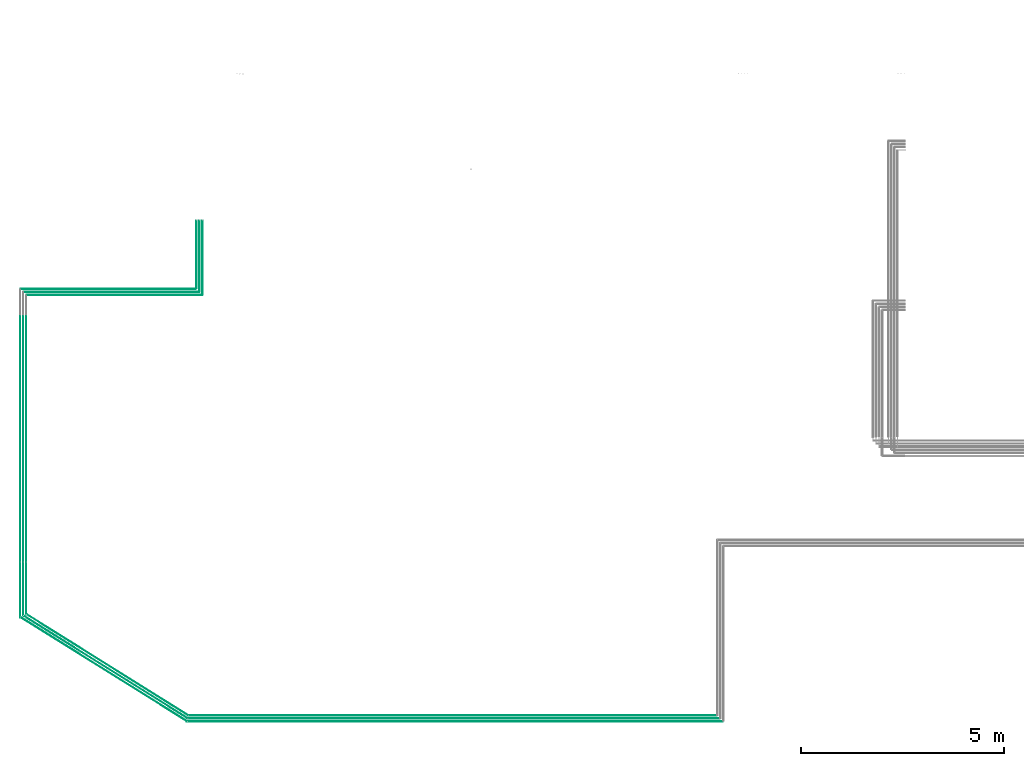
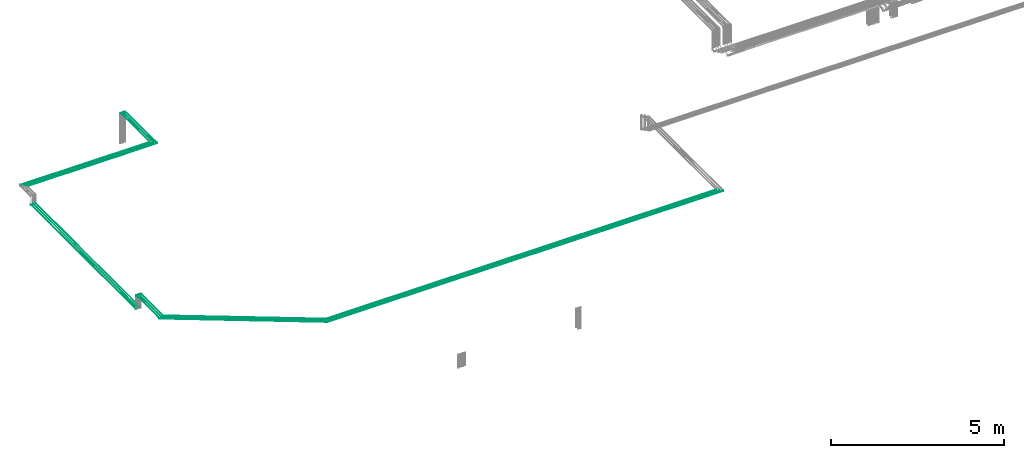
# One storey, part 1 of 65: 18 flow segments.
"""IFC2X3 building model written with IfcOpenShell, lengths in millimetres."""

from ifc_helpers import new_model, entity, si_unit, converted_unit, derived_unit, direction, frame, frame_2d, origin, origin_2d_with_axis, place, context, subcontext, project, spatial, circle, extrude, type_object, element, save


model = new_model("IFC2X3")

# Units and contexts
model_context = context("Model", 3, precision=0.01, world=origin(), true_north=direction((6.12303176911189e-17, 1.0)))
body_context = subcontext(model_context, "Body", "Model", "MODEL_VIEW")
ifc_project = project(units=[si_unit("LENGTHUNIT", "METRE", prefix="MILLI"), si_unit("AREAUNIT", "SQUARE_METRE"), si_unit("VOLUMEUNIT", "CUBIC_METRE"), converted_unit("PLANEANGLEUNIT", "DEGREE", entity("IfcRatioMeasure", 0.0174532925199433), si_unit("PLANEANGLEUNIT", "RADIAN"), dimensions=[0, 0, 0, 0, 0, 0, 0]), si_unit("MASSUNIT", "GRAM", prefix="KILO"), derived_unit("MASSDENSITYUNIT", [(si_unit("MASSUNIT", "GRAM", prefix="KILO"), 1), (si_unit("LENGTHUNIT", "METRE"), -3)]), derived_unit("MOMENTOFINERTIAUNIT", [(si_unit("LENGTHUNIT", "METRE"), 4)]), si_unit("TIMEUNIT", "SECOND"), si_unit("FREQUENCYUNIT", "HERTZ"), si_unit("THERMODYNAMICTEMPERATUREUNIT", "DEGREE_CELSIUS"), derived_unit("THERMALTRANSMITTANCEUNIT", [(si_unit("MASSUNIT", "GRAM", prefix="KILO"), 1), (si_unit("THERMODYNAMICTEMPERATUREUNIT", "KELVIN"), -1), (si_unit("TIMEUNIT", "SECOND"), -3)]), derived_unit("VOLUMETRICFLOWRATEUNIT", [(si_unit("LENGTHUNIT", "METRE"), 3), (si_unit("TIMEUNIT", "SECOND"), -1)]), derived_unit("MASSFLOWRATEUNIT", [(si_unit("MASSUNIT", "GRAM", prefix="KILO"), 1), (si_unit("TIMEUNIT", "SECOND"), -1)]), derived_unit("ROTATIONALFREQUENCYUNIT", [(si_unit("TIMEUNIT", "SECOND"), -1)]), si_unit("ELECTRICCURRENTUNIT", "AMPERE"), si_unit("ELECTRICVOLTAGEUNIT", "VOLT"), si_unit("POWERUNIT", "WATT"), si_unit("FORCEUNIT", "NEWTON", prefix="KILO"), si_unit("ILLUMINANCEUNIT", "LUX"), si_unit("LUMINOUSFLUXUNIT", "LUMEN"), si_unit("LUMINOUSINTENSITYUNIT", "CANDELA"), derived_unit("USERDEFINED", [(si_unit("MASSUNIT", "GRAM", prefix="KILO"), -1), (si_unit("LENGTHUNIT", "METRE"), -2), (si_unit("TIMEUNIT", "SECOND"), 3), (si_unit("LUMINOUSFLUXUNIT", "LUMEN"), 1)]), derived_unit("LINEARVELOCITYUNIT", [(si_unit("LENGTHUNIT", "METRE"), 1), (si_unit("TIMEUNIT", "SECOND"), -1)]), si_unit("PRESSUREUNIT", "PASCAL"), derived_unit("USERDEFINED", [(si_unit("LENGTHUNIT", "METRE"), -2), (si_unit("MASSUNIT", "GRAM", prefix="KILO"), 1), (si_unit("TIMEUNIT", "SECOND"), -2)]), derived_unit("LINEARFORCEUNIT", [(si_unit("MASSUNIT", "GRAM", prefix="KILO"), 1), (si_unit("LENGTHUNIT", "METRE"), 1), (si_unit("TIMEUNIT", "SECOND"), -2), (si_unit("LENGTHUNIT", "METRE"), -1)]), derived_unit("PLANARFORCEUNIT", [(si_unit("MASSUNIT", "GRAM", prefix="KILO"), 1), (si_unit("LENGTHUNIT", "METRE"), 1), (si_unit("TIMEUNIT", "SECOND"), -2), (si_unit("LENGTHUNIT", "METRE"), -2)])], contexts=[model_context])

# Site, building, storey
site_placement = place(None, frame((0.0, -0.00077364408347762, 0.0)))
site = spatial("IfcSite", under=ifc_project, at=site_placement, CompositionType="ELEMENT")
building_placement = place(site_placement, origin())
building = spatial("IfcBuilding", under=site, at=building_placement, CompositionType="ELEMENT")
storey_placement = place(building_placement, frame((0.0, 0.0, 19800.0)))
storey = spatial("IfcBuildingStorey", under=building, at=storey_placement, CompositionType="ELEMENT", Elevation=19800.0)

# Flow segments
pipe_segment_type = type_object("IfcPipeSegmentType", PredefinedType="NOTDEFINED")
flow_segment_1_placement = place(storey_placement, frame((16322.4047325917, 4299.93203955569, 2542.40472776409)))
element("IfcFlowSegment", 1, at=flow_segment_1_placement, inside=storey, type_object=pipe_segment_type, context=body_context, shape_type="SweptSolid", body=[
    extrude(circle(Radius=6.0, at=frame_2d((-6.49720277579036e-12, 0.0), x_axis=(1.0, 0.0))), frame((7.5952722359232, 0.0, 7.59527223591454), z_axis=(0.0, 1.0, 0.0), x_axis=(-1.0, 0.0, 0.0)), (0.0, 0.0, 1.0), 6064.81988032207),
])
flow_segment_2_placement = place(storey_placement, frame((16490.0, 10859.5344917542, 2844.40472776409)))
element("IfcFlowSegment", 2, at=flow_segment_2_placement, inside=storey, type_object=pipe_segment_type, context=body_context, shape_type="SweptSolid", body=[
    extrude(circle(Radius=4.0, at=frame_2d((-6.49720277579036e-12, 0.0), x_axis=(1.0, 0.0))), frame((0.0, 5.59527223591932, 5.59527223591499), z_axis=(1.0, 0.0, 0.0), x_axis=(0.0, 1.0, 0.0)), (0.0, 0.0, 1.0), 4325.10853012706),
])
flow_segment_3_placement = place(storey_placement, frame((16415.0, 10934.5344917542, 2844.40472776409)))
element("IfcFlowSegment", 3, at=flow_segment_3_placement, inside=storey, type_object=pipe_segment_type, context=body_context, shape_type="SweptSolid", body=[
    extrude(circle(Radius=4.0, at=frame_2d((-6.49720277579036e-12, 0.0), x_axis=(1.0, 0.0))), frame((0.0, 5.59527223591932, 5.59527223591499), z_axis=(1.0, 0.0, 0.0), x_axis=(0.0, 1.0, 0.0)), (0.0, 0.0, 1.0), 4325.10853012718),
])
flow_segment_4_placement = place(storey_placement, frame((16344.0, 11007.5344917542, 2842.40472776409)))
element("IfcFlowSegment", 4, at=flow_segment_4_placement, inside=storey, type_object=pipe_segment_type, context=body_context, shape_type="SweptSolid", body=[
    extrude(circle(Radius=6.0, at=frame_2d((-4.33146851719357e-12, 0.0), x_axis=(1.0, 0.0))), frame((0.0, 7.59527223592103, 7.59527223591454), z_axis=(1.0, 0.0, 0.0), x_axis=(0.0, 1.0, 0.0)), (0.0, 0.0, 1.0), 4317.10853012719),
])
flow_segment_5_placement = place(storey_placement, frame((20459.8637699032, 342.404727764186, 3042.40472776409)))
element("IfcFlowSegment", 5, at=flow_segment_5_placement, inside=storey, type_object=pipe_segment_type, context=body_context, shape_type="SweptSolid", body=[
    extrude(circle(Radius=6.0, at=frame_2d((3.99307253928782e-12, 0.0), x_axis=(1.0, 0.0))), frame((0.0, 7.59527223591981, 7.59527223591454), z_axis=(1.0, 0.0, 0.0), x_axis=(0.0, 1.0, 0.0)), (0.0, 0.0, 1.0), 13196.2492996041),
])
flow_segment_6_placement = place(storey_placement, frame((20471.5175600798, 419.404727764152, 3044.40472776409)))
element("IfcFlowSegment", 6, at=flow_segment_6_placement, inside=storey, type_object=pipe_segment_type, context=body_context, shape_type="SweptSolid", body=[
    extrude(circle(Radius=4.0, at=frame_2d((3.92539334370667e-12, 0.0), x_axis=(1.0, 0.0))), frame((0.0, 5.59527223591986, 5.59527223591499), z_axis=(1.0, 0.0, 0.0), x_axis=(0.0, 1.0, 0.0)), (0.0, 0.0, 1.0), 13113.5955094275),
])
flow_segment_7_placement = place(storey_placement, frame((20483.171349455, 494.404727764265, 3044.40472776409)))
element("IfcFlowSegment", 7, at=flow_segment_7_placement, inside=storey, type_object=pipe_segment_type, context=body_context, shape_type="SweptSolid", body=[
    extrude(circle(Radius=4.0, at=frame_2d((3.92539334370667e-12, 0.0), x_axis=(1.0, 0.0))), frame((0.0, 5.59527223591986, 5.59527223591499), z_axis=(1.0, 0.0, 0.0), x_axis=(0.0, 1.0, 0.0)), (0.0, 0.0, 1.0), 13026.9401950164),
])
flow_segment_8_placement = place(storey_placement, frame((16399.4047325915, 4295.93203955569, 2544.40472776409)))
element("IfcFlowSegment", 8, at=flow_segment_8_placement, inside=storey, type_object=pipe_segment_type, context=body_context, shape_type="SweptSolid", body=[
    extrude(circle(Radius=4.0, at=frame_2d((-8.66293703438714e-12, 0.0), x_axis=(1.0, 0.0))), frame((5.59527223592365, 0.0, 5.59527223591499), z_axis=(0.0, 1.0, 0.0), x_axis=(-1.0, 0.0, 0.0)), (0.0, 0.0, 1.0), 6072.81988032206),
])
flow_segment_9_placement = place(storey_placement, frame((16474.4047325923, 4295.93208240096, 2544.40472776409)))
element("IfcFlowSegment", 9, at=flow_segment_9_placement, inside=storey, type_object=pipe_segment_type, context=body_context, shape_type="SweptSolid", body=[
    extrude(circle(Radius=4.0, at=frame_2d((-8.66293703438714e-12, 0.0), x_axis=(1.0, 0.0))), frame((5.59527223592365, 0.0, 5.59527223591499), z_axis=(0.0, 1.0, 0.0), x_axis=(-1.0, 0.0, 0.0)), (0.0, 0.0, 1.0), 6072.81983747679),
])
flow_segment_10_placement = place(storey_placement, frame((20744.5132627183, 10950.1297639901, 2844.40472776409)))
element("IfcFlowSegment", 10, at=flow_segment_10_placement, inside=storey, type_object=pipe_segment_type, context=body_context, shape_type="SweptSolid", body=[
    extrude(circle(Radius=4.0, at=origin_2d_with_axis()), frame((5.59527223638279, 0.0, 5.59527223591499), z_axis=(0.0, 1.0, 0.0), x_axis=(1.0, 0.0, 0.0)), (0.0, 0.0, 1.0), 1755.00000000002),
])
flow_segment_11_placement = place(storey_placement, frame((20819.5132627192, 10875.1297639901, 2844.40472776409)))
element("IfcFlowSegment", 11, at=flow_segment_11_placement, inside=storey, type_object=pipe_segment_type, context=body_context, shape_type="SweptSolid", body=[
    extrude(circle(Radius=4.0, at=origin_2d_with_axis()), frame((5.59527223607525, 0.0, 5.59527223591499), z_axis=(0.0, 1.0, 0.0), x_axis=(1.0, 0.0, 0.0)), (0.0, 0.0, 1.0), 1830.00000000002),
])
flow_segment_12_placement = place(storey_placement, frame((20667.5132627186, 11029.1297639901, 2842.40472776409)))
element("IfcFlowSegment", 12, at=flow_segment_12_placement, inside=storey, type_object=pipe_segment_type, context=body_context, shape_type="SweptSolid", body=[
    extrude(circle(Radius=6.0, at=origin_2d_with_axis()), frame((7.59527223617876, 0.0, 7.59527223591454), z_axis=(0.0, 1.0, 0.0), x_axis=(1.0, 0.0, 0.0)), (0.0, 0.0, 1.0), 1672.00000000001),
])
flow_segment_13_placement = place(storey_placement, frame((16332.8576498727, 348.08571256534, 3042.40472776407)))
element("IfcFlowSegment", 13, at=flow_segment_13_placement, inside=storey, type_object=pipe_segment_type, context=body_context, shape_type="SweptSolid", body=[
    extrude(circle(Radius=6.0, at=frame_2d((4.59161703695938e-13, 0.0), x_axis=(1.0, 0.0))), frame((4.7747878213135, 2572.1464842454, 7.59527223591454), z_axis=(0.848048096156426, -0.529919264233205, 0.0), x_axis=(0.529919264233205, 0.848048096156426, 0.0)), (0.0, 0.0, 1.0), 4841.23355497327),
])
flow_segment_14_placement = place(storey_placement, frame((16483.9174884007, 499.781808757731, 3044.40472760222)))
element("IfcFlowSegment", 14, at=flow_segment_14_placement, inside=storey, type_object=pipe_segment_type, context=body_context, shape_type="SweptSolid", body=[
    extrude(circle(Radius=4.0, at=frame_2d((-5.73952129619922e-14, 2.1110668143692e-22), x_axis=(1.0, 0.0))), frame((3982.62142818889, 4.98746462054189, 5.59527223591499), z_axis=(-0.848048096156425, 0.529919264233206, 0.0), x_axis=(0.529919264233206, 0.848048096156425, -3.67812349745469e-09)), (0.0, 0.0, 1.0), 4691.84058891173),
])
flow_segment_15_placement = place(storey_placement, frame((16408.9174884013, 424.781808757618, 3044.40472776407)))
element("IfcFlowSegment", 15, at=flow_segment_15_placement, inside=storey, type_object=pipe_segment_type, context=body_context, shape_type="SweptSolid", body=[
    extrude(circle(Radius=4.0, at=origin_2d_with_axis()), frame((3.71494929284691, 2530.86728297481, 5.59527223591499), z_axis=(0.848048096156426, -0.529919264233205, 0.0), x_axis=(0.529919264233205, 0.848048096156426, 0.0)), (0.0, 0.0, 1.0), 4766.53707241465),
])
flow_segment_16_placement = place(storey_placement, frame((16322.4047325917, 2934.00147018883, 3042.40472776409)))
element("IfcFlowSegment", 16, at=flow_segment_16_placement, inside=storey, type_object=pipe_segment_type, context=body_context, shape_type="SweptSolid", body=[
    extrude(circle(Radius=6.0, at=frame_2d((-2.16573425859679e-12, 0.0), x_axis=(1.0, 0.0))), frame((7.59527223698874, 0.0, 7.59527223591454), z_axis=(0.0, 1.0, 0.0), x_axis=(1.0, 0.0, 0.0)), (0.0, 0.0, 1.0), 1337.93056936686),
])
flow_segment_17_placement = place(storey_placement, frame((16399.4047325915, 2969.41836511053, 3044.40472776409)))
element("IfcFlowSegment", 17, at=flow_segment_17_placement, inside=storey, type_object=pipe_segment_type, context=body_context, shape_type="SweptSolid", body=[
    extrude(circle(Radius=4.0, at=origin_2d_with_axis()), frame((5.59527223722309, 0.0, 5.59527223591499), z_axis=(0.0, 1.0, 0.0), x_axis=(1.0, 0.0, 0.0)), (0.0, 0.0, 1.0), 1306.51367444517),
])
flow_segment_18_placement = place(storey_placement, frame((16474.4047325922, 3004.83525953197, 3044.4046435028)))
element("IfcFlowSegment", 18, at=flow_segment_18_placement, inside=storey, type_object=pipe_segment_type, context=body_context, shape_type="SweptSolid", body=[
    extrude(circle(Radius=4.0, at=origin_2d_with_axis()), frame((5.59527223591499, 0.0, 5.59527223591499), z_axis=(0.0, 1.0, 0.0), x_axis=(1.0, 0.0, 0.0)), (0.0, 0.0, 1.0), 1271.09673717845),
])

save(model, "model.ifc")
